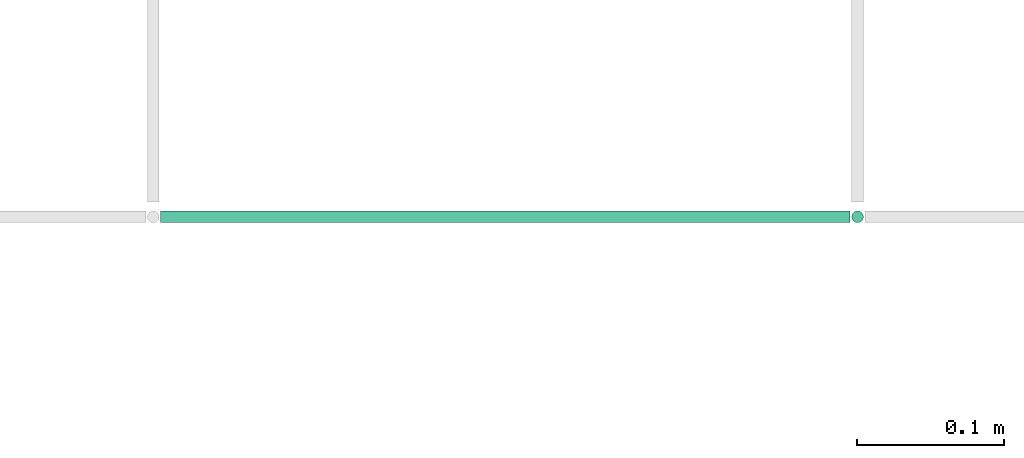
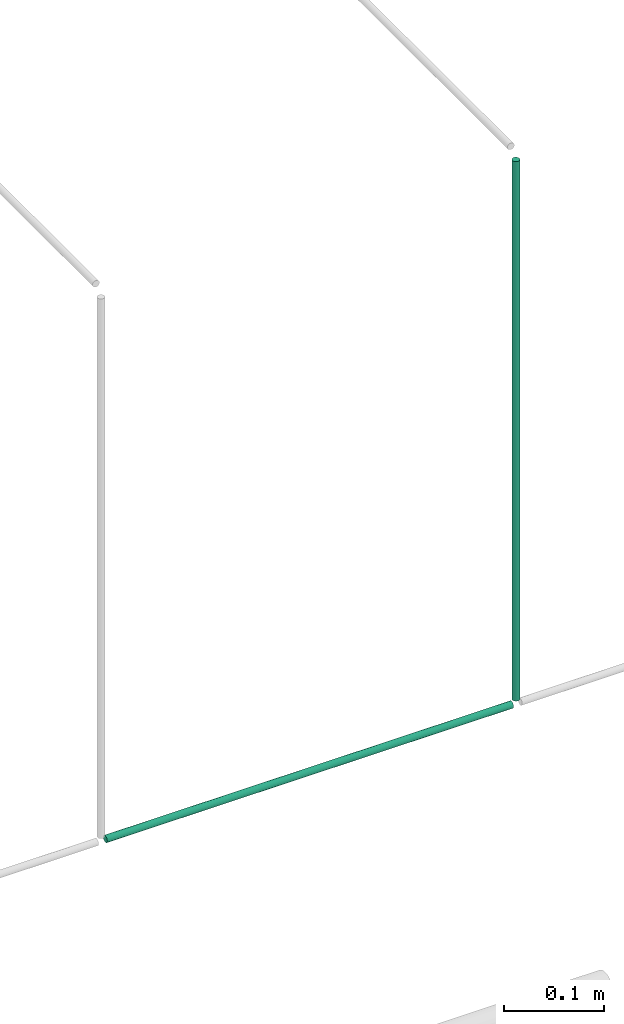
# One storey, part 245 of 331: 2 flow segments.
"""IFC2X3 building model written with IfcOpenShell, lengths in millimetres."""

from ifc_helpers import new_model, entity, si_unit, converted_unit, derived_unit, direction, frame, origin, origin_2d_with_axis, place, context, subcontext, project, spatial, circle, extrude, type_object, element, save


model = new_model("IFC2X3")

# Units and contexts
model_context = context("Model", 3, precision=0.01, world=origin(), true_north=direction((6.12303176911189e-17, 1.0)))
body_context = subcontext(model_context, "Body", "Model", "MODEL_VIEW")
ifc_project = project(units=[si_unit("LENGTHUNIT", "METRE", prefix="MILLI"), si_unit("AREAUNIT", "SQUARE_METRE"), si_unit("VOLUMEUNIT", "CUBIC_METRE"), converted_unit("PLANEANGLEUNIT", "DEGREE", entity("IfcRatioMeasure", 0.0174532925199433), si_unit("PLANEANGLEUNIT", "RADIAN"), dimensions=[0, 0, 0, 0, 0, 0, 0]), si_unit("MASSUNIT", "GRAM", prefix="KILO"), derived_unit("MASSDENSITYUNIT", [(si_unit("MASSUNIT", "GRAM", prefix="KILO"), 1), (si_unit("LENGTHUNIT", "METRE"), -3)]), derived_unit("MOMENTOFINERTIAUNIT", [(si_unit("LENGTHUNIT", "METRE"), 4)]), si_unit("TIMEUNIT", "SECOND"), si_unit("FREQUENCYUNIT", "HERTZ"), si_unit("THERMODYNAMICTEMPERATUREUNIT", "DEGREE_CELSIUS"), derived_unit("THERMALTRANSMITTANCEUNIT", [(si_unit("MASSUNIT", "GRAM", prefix="KILO"), 1), (si_unit("THERMODYNAMICTEMPERATUREUNIT", "KELVIN"), -1), (si_unit("TIMEUNIT", "SECOND"), -3)]), derived_unit("VOLUMETRICFLOWRATEUNIT", [(si_unit("LENGTHUNIT", "METRE"), 3), (si_unit("TIMEUNIT", "SECOND"), -1)]), derived_unit("MASSFLOWRATEUNIT", [(si_unit("MASSUNIT", "GRAM", prefix="KILO"), 1), (si_unit("TIMEUNIT", "SECOND"), -1)]), derived_unit("ROTATIONALFREQUENCYUNIT", [(si_unit("TIMEUNIT", "SECOND"), -1)]), si_unit("ELECTRICCURRENTUNIT", "AMPERE"), si_unit("ELECTRICVOLTAGEUNIT", "VOLT"), si_unit("POWERUNIT", "WATT"), si_unit("FORCEUNIT", "NEWTON", prefix="KILO"), si_unit("ILLUMINANCEUNIT", "LUX"), si_unit("LUMINOUSFLUXUNIT", "LUMEN"), si_unit("LUMINOUSINTENSITYUNIT", "CANDELA"), derived_unit("USERDEFINED", [(si_unit("MASSUNIT", "GRAM", prefix="KILO"), -1), (si_unit("LENGTHUNIT", "METRE"), -2), (si_unit("TIMEUNIT", "SECOND"), 3), (si_unit("LUMINOUSFLUXUNIT", "LUMEN"), 1)]), derived_unit("LINEARVELOCITYUNIT", [(si_unit("LENGTHUNIT", "METRE"), 1), (si_unit("TIMEUNIT", "SECOND"), -1)]), si_unit("PRESSUREUNIT", "PASCAL"), derived_unit("USERDEFINED", [(si_unit("LENGTHUNIT", "METRE"), -2), (si_unit("MASSUNIT", "GRAM", prefix="KILO"), 1), (si_unit("TIMEUNIT", "SECOND"), -2)]), derived_unit("LINEARFORCEUNIT", [(si_unit("MASSUNIT", "GRAM", prefix="KILO"), 1), (si_unit("LENGTHUNIT", "METRE"), 1), (si_unit("TIMEUNIT", "SECOND"), -2), (si_unit("LENGTHUNIT", "METRE"), -1)]), derived_unit("PLANARFORCEUNIT", [(si_unit("MASSUNIT", "GRAM", prefix="KILO"), 1), (si_unit("LENGTHUNIT", "METRE"), 1), (si_unit("TIMEUNIT", "SECOND"), -2), (si_unit("LENGTHUNIT", "METRE"), -2)])], contexts=[model_context])

# Site, building, storey
site_placement = place(None, frame((0.0, -0.00077364408347762, 0.0)))
site = spatial("IfcSite", under=ifc_project, at=site_placement, CompositionType="ELEMENT")
building_placement = place(site_placement, origin())
building = spatial("IfcBuilding", under=site, at=building_placement, CompositionType="ELEMENT")
storey_placement = place(building_placement, origin())
storey = spatial("IfcBuildingStorey", under=building, at=storey_placement, CompositionType="ELEMENT", Elevation=0.0)

# Flow segments
pipe_segment_type = type_object("IfcPipeSegmentType", PredefinedType="NOTDEFINED")
flow_segment_1_placement = place(building_placement, frame((60319.9807073846, 16292.9115686369, 6669.40472776409)))
element("IfcFlowSegment", 1, at=flow_segment_1_placement, inside=storey, type_object=pipe_segment_type, context=body_context, shape_type="SweptSolid", body=[
    extrude(circle(Radius=4.0, at=origin_2d_with_axis()), frame((0.0, 5.59527223591499, 5.59527223591607), z_axis=(1.0, 0.0, 0.0), x_axis=(0.0, 1.0, 0.0)), (0.0, 0.0, 1.0), 470.019561170245),
])
flow_segment_2_placement = place(storey_placement, frame((60789.4049963189, 16292.9115686369, 6680.0)))
element("IfcFlowSegment", 2, at=flow_segment_2_placement, inside=storey, type_object=pipe_segment_type, context=body_context, shape_type="SweptSolid", body=[
    extrude(circle(Radius=4.0, at=origin_2d_with_axis()), frame((5.59527223591499, 5.59527223591499, 0.0), z_axis=(0.0, 0.0, 1.0), x_axis=(-1.0, 0.0, 0.0)), (0.0, 0.0, 1.0), 660.000000000011),
])

save(model, "model.ifc")
